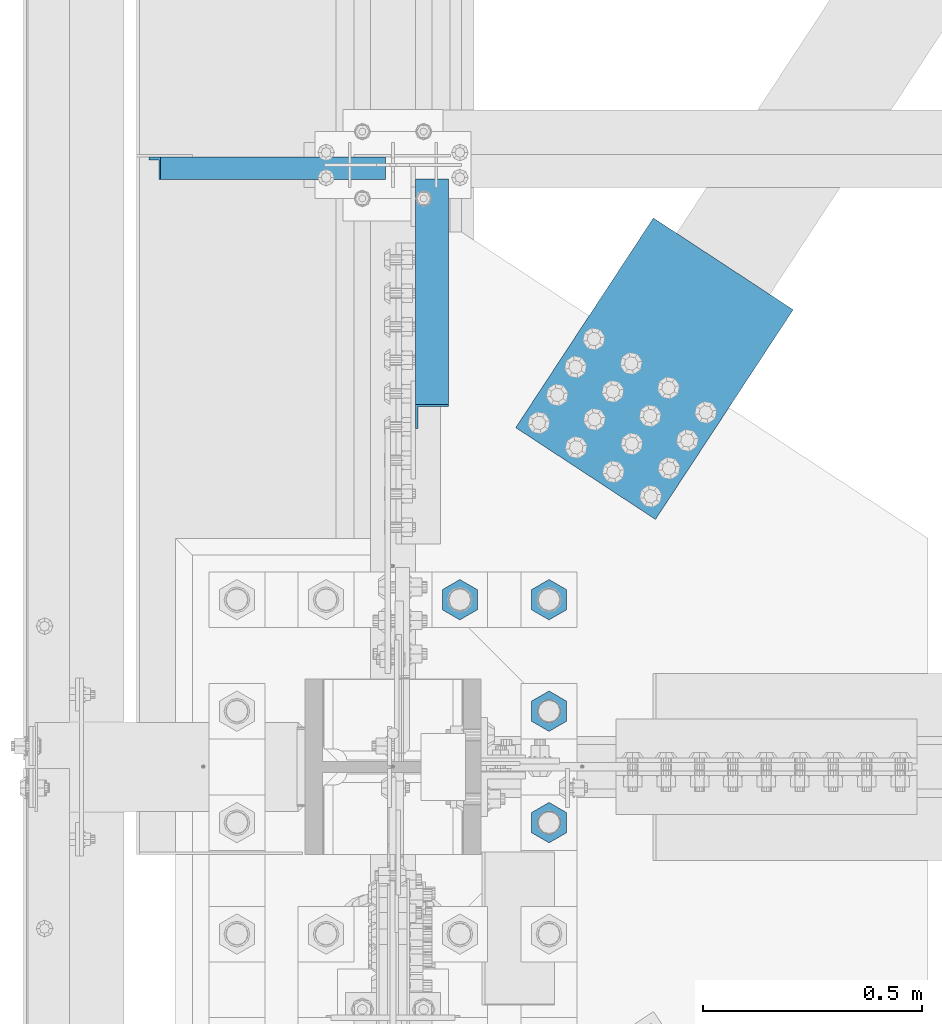
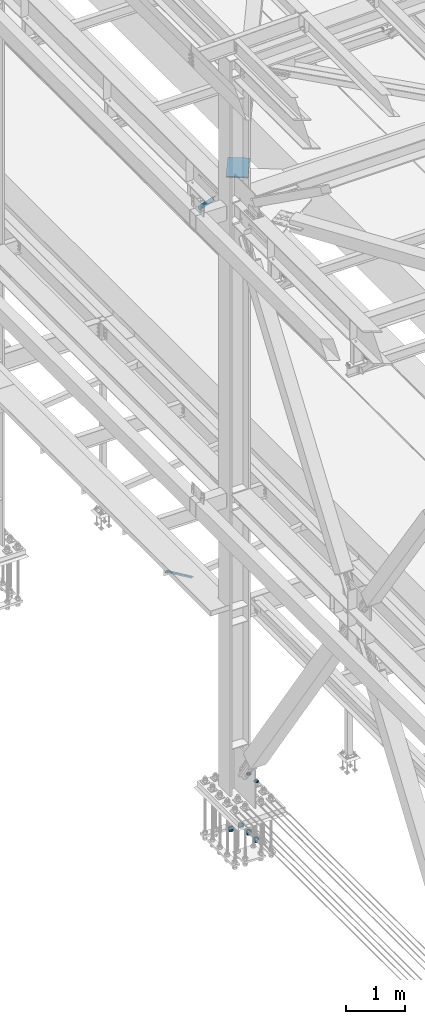
# One storey, part 2217 of 3843: 11 beams, 2 members, 4 elements without a shape of their own.
"""IFC2X3 building model written with IfcOpenShell, lengths in millimetres."""

from ifc_helpers import new_model, si_unit, frame, origin_with_axes, place, context, subcontext, project, spatial, faceted_brep, material, type_object, element, aggregate, save


model = new_model("IFC2X3")

# Units and contexts
model_context = context("Model", 3, precision=1e-05, world=origin_with_axes())
body_context = subcontext(model_context, "Body", "Model", "MODEL_VIEW")
ifc_project = project(units=[si_unit("LENGTHUNIT", "METRE", prefix="MILLI"), si_unit("AREAUNIT", "SQUARE_METRE"), si_unit("VOLUMEUNIT", "CUBIC_METRE"), si_unit("MASSUNIT", "GRAM", prefix="KILO"), si_unit("TIMEUNIT", "SECOND"), si_unit("PLANEANGLEUNIT", "RADIAN"), si_unit("SOLIDANGLEUNIT", "STERADIAN"), si_unit("THERMODYNAMICTEMPERATUREUNIT", "DEGREE_CELSIUS"), si_unit("LUMINOUSINTENSITYUNIT", "LUMEN")], contexts=[model_context])

# Site, building, storey
site_placement = place(None, origin_with_axes())
site = spatial("IfcSite", under=ifc_project, at=site_placement, CompositionType="ELEMENT")
building_placement = place(site_placement, origin_with_axes())
building = spatial("IfcBuilding", under=site, at=building_placement, Name="Undefined", CompositionType="ELEMENT")
storey_placement = place(building_placement, origin_with_axes())
storey = spatial("IfcBuildingStorey", under=building, at=storey_placement, Name="Undefined", CompositionType="ELEMENT", Elevation=0.0)

# Assembly, beams
assembly_1_placement = place(storey_placement, origin_with_axes())
assembly_1 = element("IfcElementAssembly", 1, at=assembly_1_placement, inside=storey, Name="TEMPLATE", AssemblyPlace="NOTDEFINED", PredefinedType="RIGID_FRAME")
ifc_material = material(Name="STEEL/A572-50")
beam_type_1 = type_object("IfcBeamType", Name="2_HALF_NUT", PredefinedType="NOTDEFINED")
beam_1_placement = place(assembly_1_placement, frame((36931.6, 59042.3, 30257.75), z_axis=(1.0, 0.0, 0.0), x_axis=(0.0, 0.0, -1.0)))
beam_1 = element("IfcBeam", 2, at=beam_1_placement, type_object=beam_type_1, material=ifc_material, Name="NUT", ObjectType="2_HALF_NUT", context=body_context, shape_type="Brep", body=[
    faceted_brep([(0.0, -46.0369987487793, 0.0), (0.0, -23.0184993743896, -39.869213104248), (25.4000000000015, -23.0184993743896, -39.869213104248), (25.4000000000015, -46.0369987487793, 0.0), (0.0, 23.0184993743896, -39.869213104248), (25.4000000000015, 23.0184993743896, -39.869213104248), (0.0, 46.0369987487793, 0.0), (25.4000000000015, 46.0369987487793, 0.0), (0.0, 23.0184993743896, 39.869213104248), (25.4000000000015, 23.0184993743896, 39.869213104248), (0.0, -23.0184993743896, 39.869213104248), (25.4000000000015, -23.0184993743896, 39.869213104248), (0.0, 0.0, 26.1940002441406), (0.0, 11.3650617044477, 23.5999013092805), (25.4000000000015, 11.3650617044477, 23.5999013092805), (25.4000000000015, 0.0, 26.1940002441406), (0.0, 20.4791109456419, 16.3316083006721), (25.4000000000015, 20.4791109456419, 16.3316083006721), (0.0, 25.5370200498292, 5.82867859874386), (25.4000000000015, 25.5370200498292, 5.82867859874386), (0.0, 25.5370200498292, -5.82867859874386), (25.4000000000015, 25.5370200498292, -5.82867859874386), (0.0, 20.4791109456419, -16.3316083006721), (25.4000000000015, 20.4791109456419, -16.3316083006721), (0.0, 11.3650617044477, -23.5999013092805), (25.4000000000015, 11.3650617044477, -23.5999013092805), (0.0, 0.0, -26.1940002441406), (25.4000000000015, 0.0, -26.1940002441406), (0.0, -11.3650617044477, -23.5999013092805), (25.4000000000015, -11.3650617044477, -23.5999013092805), (0.0, -20.4791109456419, -16.3316083006721), (25.4000000000015, -20.4791109456419, -16.3316083006721), (0.0, -25.5370200498292, -5.82867859874386), (25.4000000000015, -25.5370200498292, -5.82867859874386), (0.0, -25.5370200498292, 5.82867859874386), (25.4000000000015, -25.5370200498292, 5.82867859874386), (0.0, -20.4791109456419, 16.3316083006721), (25.4000000000015, -20.4791109456419, 16.3316083006721), (0.0, -11.3650617044477, 23.5999013092805), (25.4000000000015, -11.3650617044477, 23.5999013092805)], [[[0, 1, 2, 3]], [[1, 4, 5, 2]], [[4, 6, 7, 5]], [[6, 8, 9, 7]], [[8, 10, 11, 9]], [[10, 0, 3, 11]], [[12, 13, 14, 15]], [[13, 16, 17, 14]], [[16, 18, 19, 17]], [[18, 20, 21, 19]], [[20, 22, 23, 21]], [[22, 24, 25, 23]], [[24, 26, 27, 25]], [[26, 28, 29, 27]], [[28, 30, 31, 29]], [[30, 32, 33, 31]], [[32, 34, 35, 33]], [[34, 36, 37, 35]], [[36, 38, 39, 37]], [[38, 12, 15, 39]], [[5, 7, 9, 11, 3, 2], [17, 19, 21, 23, 25, 27, 29, 31, 33, 35, 37, 39, 15, 14]], [[10, 8, 6, 4, 1, 0], [38, 36, 34, 32, 30, 28, 26, 24, 22, 20, 18, 16, 13, 12]]]),
])
beam_2_placement = place(assembly_1_placement, frame((36931.6, 58788.3, 30257.75), z_axis=(1.0, 0.0, 0.0), x_axis=(0.0, 0.0, -1.0)))
beam_2 = element("IfcBeam", 3, at=beam_2_placement, type_object=beam_type_1, material=ifc_material, Name="NUT", ObjectType="2_HALF_NUT", context=body_context, shape_type="Brep", body=[
    faceted_brep([(0.0, -46.0369987487793, 0.0), (0.0, -23.0184993743896, -39.869213104248), (25.4000000000015, -23.0184993743896, -39.869213104248), (25.4000000000015, -46.0369987487793, 0.0), (0.0, 23.0184993743896, -39.869213104248), (25.4000000000015, 23.0184993743896, -39.869213104248), (0.0, 46.0369987487793, 0.0), (25.4000000000015, 46.0369987487793, 0.0), (0.0, 23.0184993743896, 39.869213104248), (25.4000000000015, 23.0184993743896, 39.869213104248), (0.0, -23.0184993743896, 39.869213104248), (25.4000000000015, -23.0184993743896, 39.869213104248), (0.0, 0.0, 26.1940002441406), (0.0, 11.3650617044477, 23.5999013092805), (25.4000000000015, 11.3650617044477, 23.5999013092805), (25.4000000000015, 0.0, 26.1940002441406), (0.0, 20.4791109456419, 16.3316083006721), (25.4000000000015, 20.4791109456419, 16.3316083006721), (0.0, 25.5370200498292, 5.82867859874386), (25.4000000000015, 25.5370200498292, 5.82867859874386), (0.0, 25.5370200498292, -5.82867859874386), (25.4000000000015, 25.5370200498292, -5.82867859874386), (0.0, 20.4791109456419, -16.3316083006721), (25.4000000000015, 20.4791109456419, -16.3316083006721), (0.0, 11.3650617044477, -23.5999013092805), (25.4000000000015, 11.3650617044477, -23.5999013092805), (0.0, 0.0, -26.1940002441406), (25.4000000000015, 0.0, -26.1940002441406), (0.0, -11.3650617044477, -23.5999013092805), (25.4000000000015, -11.3650617044477, -23.5999013092805), (0.0, -20.4791109456419, -16.3316083006721), (25.4000000000015, -20.4791109456419, -16.3316083006721), (0.0, -25.5370200498292, -5.82867859874386), (25.4000000000015, -25.5370200498292, -5.82867859874386), (0.0, -25.5370200498292, 5.82867859874386), (25.4000000000015, -25.5370200498292, 5.82867859874386), (0.0, -20.4791109456419, 16.3316083006721), (25.4000000000015, -20.4791109456419, 16.3316083006721), (0.0, -11.3650617044477, 23.5999013092805), (25.4000000000015, -11.3650617044477, 23.5999013092805)], [[[0, 1, 2, 3]], [[1, 4, 5, 2]], [[4, 6, 7, 5]], [[6, 8, 9, 7]], [[8, 10, 11, 9]], [[10, 0, 3, 11]], [[12, 13, 14, 15]], [[13, 16, 17, 14]], [[16, 18, 19, 17]], [[18, 20, 21, 19]], [[20, 22, 23, 21]], [[22, 24, 25, 23]], [[24, 26, 27, 25]], [[26, 28, 29, 27]], [[28, 30, 31, 29]], [[30, 32, 33, 31]], [[32, 34, 35, 33]], [[34, 36, 37, 35]], [[36, 38, 39, 37]], [[38, 12, 15, 39]], [[5, 7, 9, 11, 3, 2], [17, 19, 21, 23, 25, 27, 29, 31, 33, 35, 37, 39, 15, 14]], [[10, 8, 6, 4, 1, 0], [38, 36, 34, 32, 30, 28, 26, 24, 22, 20, 18, 16, 13, 12]]]),
])
beam_3_placement = place(assembly_1_placement, frame((36931.6, 59296.3, 29057.6), z_axis=(1.0, 0.0, 0.0), x_axis=(0.0, 0.0, -1.0)))
beam_3 = element("IfcBeam", 4, at=beam_3_placement, type_object=beam_type_1, material=ifc_material, Name="NUT", ObjectType="2_HALF_NUT", context=body_context, shape_type="Brep", body=[
    faceted_brep([(0.0, -46.0369987487793, 0.0), (0.0, -23.0184993743896, -39.869213104248), (25.4000000000015, -23.0184993743896, -39.869213104248), (25.4000000000015, -46.0369987487793, 0.0), (0.0, 23.0184993743896, -39.869213104248), (25.4000000000015, 23.0184993743896, -39.869213104248), (0.0, 46.0369987487793, 0.0), (25.4000000000015, 46.0369987487793, 0.0), (0.0, 23.0184993743896, 39.869213104248), (25.4000000000015, 23.0184993743896, 39.869213104248), (0.0, -23.0184993743896, 39.869213104248), (25.4000000000015, -23.0184993743896, 39.869213104248), (0.0, 0.0, 26.1940002441406), (0.0, 11.3650617044477, 23.5999013092805), (25.4000000000015, 11.3650617044477, 23.5999013092805), (25.4000000000015, 0.0, 26.1940002441406), (0.0, 20.4791109456419, 16.3316083006721), (25.4000000000015, 20.4791109456419, 16.3316083006721), (0.0, 25.5370200498292, 5.82867859874386), (25.4000000000015, 25.5370200498292, 5.82867859874386), (0.0, 25.5370200498292, -5.82867859874386), (25.4000000000015, 25.5370200498292, -5.82867859874386), (0.0, 20.4791109456419, -16.3316083006721), (25.4000000000015, 20.4791109456419, -16.3316083006721), (0.0, 11.3650617044477, -23.5999013092805), (25.4000000000015, 11.3650617044477, -23.5999013092805), (0.0, 0.0, -26.1940002441406), (25.4000000000015, 0.0, -26.1940002441406), (0.0, -11.3650617044477, -23.5999013092805), (25.4000000000015, -11.3650617044477, -23.5999013092805), (0.0, -20.4791109456419, -16.3316083006721), (25.4000000000015, -20.4791109456419, -16.3316083006721), (0.0, -25.5370200498292, -5.82867859874386), (25.4000000000015, -25.5370200498292, -5.82867859874386), (0.0, -25.5370200498292, 5.82867859874386), (25.4000000000015, -25.5370200498292, 5.82867859874386), (0.0, -20.4791109456419, 16.3316083006721), (25.4000000000015, -20.4791109456419, 16.3316083006721), (0.0, -11.3650617044477, 23.5999013092805), (25.4000000000015, -11.3650617044477, 23.5999013092805)], [[[0, 1, 2, 3]], [[1, 4, 5, 2]], [[4, 6, 7, 5]], [[6, 8, 9, 7]], [[8, 10, 11, 9]], [[10, 0, 3, 11]], [[12, 13, 14, 15]], [[13, 16, 17, 14]], [[16, 18, 19, 17]], [[18, 20, 21, 19]], [[20, 22, 23, 21]], [[22, 24, 25, 23]], [[24, 26, 27, 25]], [[26, 28, 29, 27]], [[28, 30, 31, 29]], [[30, 32, 33, 31]], [[32, 34, 35, 33]], [[34, 36, 37, 35]], [[36, 38, 39, 37]], [[38, 12, 15, 39]], [[5, 7, 9, 11, 3, 2], [17, 19, 21, 23, 25, 27, 29, 31, 33, 35, 37, 39, 15, 14]], [[10, 8, 6, 4, 1, 0], [38, 36, 34, 32, 30, 28, 26, 24, 22, 20, 18, 16, 13, 12]]]),
])
beam_4_placement = place(assembly_1_placement, frame((36728.4, 59296.3, 29057.6), z_axis=(1.0, 0.0, 0.0), x_axis=(0.0, 0.0, -1.0)))
beam_4 = element("IfcBeam", 5, at=beam_4_placement, type_object=beam_type_1, material=ifc_material, Name="NUT", ObjectType="2_HALF_NUT", context=body_context, shape_type="Brep", body=[
    faceted_brep([(0.0, -46.0369987487793, 0.0), (0.0, -23.0184993743896, -39.869213104248), (25.4000000000015, -23.0184993743896, -39.869213104248), (25.4000000000015, -46.0369987487793, 0.0), (0.0, 23.0184993743896, -39.869213104248), (25.4000000000015, 23.0184993743896, -39.869213104248), (0.0, 46.0369987487793, 0.0), (25.4000000000015, 46.0369987487793, 0.0), (0.0, 23.0184993743896, 39.869213104248), (25.4000000000015, 23.0184993743896, 39.869213104248), (0.0, -23.0184993743896, 39.869213104248), (25.4000000000015, -23.0184993743896, 39.869213104248), (0.0, 0.0, 26.1940002441406), (0.0, 11.3650617044477, 23.5999013092805), (25.4000000000015, 11.3650617044477, 23.5999013092805), (25.4000000000015, 0.0, 26.1940002441406), (0.0, 20.4791109456419, 16.3316083006721), (25.4000000000015, 20.4791109456419, 16.3316083006721), (0.0, 25.5370200498292, 5.82867859874386), (25.4000000000015, 25.5370200498292, 5.82867859874386), (0.0, 25.5370200498292, -5.82867859874386), (25.4000000000015, 25.5370200498292, -5.82867859874386), (0.0, 20.4791109456419, -16.3316083006721), (25.4000000000015, 20.4791109456419, -16.3316083006721), (0.0, 11.3650617044477, -23.5999013092805), (25.4000000000015, 11.3650617044477, -23.5999013092805), (0.0, 0.0, -26.1940002441406), (25.4000000000015, 0.0, -26.1940002441406), (0.0, -11.3650617044477, -23.5999013092805), (25.4000000000015, -11.3650617044477, -23.5999013092805), (0.0, -20.4791109456419, -16.3316083006721), (25.4000000000015, -20.4791109456419, -16.3316083006721), (0.0, -25.5370200498292, -5.82867859874386), (25.4000000000015, -25.5370200498292, -5.82867859874386), (0.0, -25.5370200498292, 5.82867859874386), (25.4000000000015, -25.5370200498292, 5.82867859874386), (0.0, -20.4791109456419, 16.3316083006721), (25.4000000000015, -20.4791109456419, 16.3316083006721), (0.0, -11.3650617044477, 23.5999013092805), (25.4000000000015, -11.3650617044477, 23.5999013092805)], [[[0, 1, 2, 3]], [[1, 4, 5, 2]], [[4, 6, 7, 5]], [[6, 8, 9, 7]], [[8, 10, 11, 9]], [[10, 0, 3, 11]], [[12, 13, 14, 15]], [[13, 16, 17, 14]], [[16, 18, 19, 17]], [[18, 20, 21, 19]], [[20, 22, 23, 21]], [[22, 24, 25, 23]], [[24, 26, 27, 25]], [[26, 28, 29, 27]], [[28, 30, 31, 29]], [[30, 32, 33, 31]], [[32, 34, 35, 33]], [[34, 36, 37, 35]], [[36, 38, 39, 37]], [[38, 12, 15, 39]], [[5, 7, 9, 11, 3, 2], [17, 19, 21, 23, 25, 27, 29, 31, 33, 35, 37, 39, 15, 14]], [[10, 8, 6, 4, 1, 0], [38, 36, 34, 32, 30, 28, 26, 24, 22, 20, 18, 16, 13, 12]]]),
])
beam_5_placement = place(assembly_1_placement, frame((36931.6, 59042.3, 29070.3), z_axis=(1.0, 0.0, 0.0), x_axis=(0.0, 0.0, -1.0)))
beam_5 = element("IfcBeam", 6, at=beam_5_placement, type_object=beam_type_1, material=ifc_material, Name="NUT", ObjectType="2_HALF_NUT", context=body_context, shape_type="Brep", body=[
    faceted_brep([(0.0, -46.0369987487793, 0.0), (0.0, -23.0184993743896, -39.869213104248), (25.4000000000015, -23.0184993743896, -39.869213104248), (25.4000000000015, -46.0369987487793, 0.0), (0.0, 23.0184993743896, -39.869213104248), (25.4000000000015, 23.0184993743896, -39.869213104248), (0.0, 46.0369987487793, 0.0), (25.4000000000015, 46.0369987487793, 0.0), (0.0, 23.0184993743896, 39.869213104248), (25.4000000000015, 23.0184993743896, 39.869213104248), (0.0, -23.0184993743896, 39.869213104248), (25.4000000000015, -23.0184993743896, 39.869213104248), (0.0, 0.0, 26.1940002441406), (0.0, 11.3650617044477, 23.5999013092805), (25.4000000000015, 11.3650617044477, 23.5999013092805), (25.4000000000015, 0.0, 26.1940002441406), (0.0, 20.4791109456419, 16.3316083006721), (25.4000000000015, 20.4791109456419, 16.3316083006721), (0.0, 25.5370200498292, 5.82867859874386), (25.4000000000015, 25.5370200498292, 5.82867859874386), (0.0, 25.5370200498292, -5.82867859874386), (25.4000000000015, 25.5370200498292, -5.82867859874386), (0.0, 20.4791109456419, -16.3316083006721), (25.4000000000015, 20.4791109456419, -16.3316083006721), (0.0, 11.3650617044477, -23.5999013092805), (25.4000000000015, 11.3650617044477, -23.5999013092805), (0.0, 0.0, -26.1940002441406), (25.4000000000015, 0.0, -26.1940002441406), (0.0, -11.3650617044477, -23.5999013092805), (25.4000000000015, -11.3650617044477, -23.5999013092805), (0.0, -20.4791109456419, -16.3316083006721), (25.4000000000015, -20.4791109456419, -16.3316083006721), (0.0, -25.5370200498292, -5.82867859874386), (25.4000000000015, -25.5370200498292, -5.82867859874386), (0.0, -25.5370200498292, 5.82867859874386), (25.4000000000015, -25.5370200498292, 5.82867859874386), (0.0, -20.4791109456419, 16.3316083006721), (25.4000000000015, -20.4791109456419, 16.3316083006721), (0.0, -11.3650617044477, 23.5999013092805), (25.4000000000015, -11.3650617044477, 23.5999013092805)], [[[0, 1, 2, 3]], [[1, 4, 5, 2]], [[4, 6, 7, 5]], [[6, 8, 9, 7]], [[8, 10, 11, 9]], [[10, 0, 3, 11]], [[12, 13, 14, 15]], [[13, 16, 17, 14]], [[16, 18, 19, 17]], [[18, 20, 21, 19]], [[20, 22, 23, 21]], [[22, 24, 25, 23]], [[24, 26, 27, 25]], [[26, 28, 29, 27]], [[28, 30, 31, 29]], [[30, 32, 33, 31]], [[32, 34, 35, 33]], [[34, 36, 37, 35]], [[36, 38, 39, 37]], [[38, 12, 15, 39]], [[5, 7, 9, 11, 3, 2], [17, 19, 21, 23, 25, 27, 29, 31, 33, 35, 37, 39, 15, 14]], [[10, 8, 6, 4, 1, 0], [38, 36, 34, 32, 30, 28, 26, 24, 22, 20, 18, 16, 13, 12]]]),
])
beam_6_placement = place(assembly_1_placement, frame((36931.6, 58788.3, 29070.3), z_axis=(1.0, 0.0, 0.0), x_axis=(0.0, 0.0, -1.0)))
beam_6 = element("IfcBeam", 7, at=beam_6_placement, type_object=beam_type_1, material=ifc_material, Name="NUT", ObjectType="2_HALF_NUT", context=body_context, shape_type="Brep", body=[
    faceted_brep([(0.0, -46.0369987487793, 0.0), (0.0, -23.0184993743896, -39.869213104248), (25.4000000000015, -23.0184993743896, -39.869213104248), (25.4000000000015, -46.0369987487793, 0.0), (0.0, 23.0184993743896, -39.869213104248), (25.4000000000015, 23.0184993743896, -39.869213104248), (0.0, 46.0369987487793, 0.0), (25.4000000000015, 46.0369987487793, 0.0), (0.0, 23.0184993743896, 39.869213104248), (25.4000000000015, 23.0184993743896, 39.869213104248), (0.0, -23.0184993743896, 39.869213104248), (25.4000000000015, -23.0184993743896, 39.869213104248), (0.0, 0.0, 26.1940002441406), (0.0, 11.3650617044477, 23.5999013092805), (25.4000000000015, 11.3650617044477, 23.5999013092805), (25.4000000000015, 0.0, 26.1940002441406), (0.0, 20.4791109456419, 16.3316083006721), (25.4000000000015, 20.4791109456419, 16.3316083006721), (0.0, 25.5370200498292, 5.82867859874386), (25.4000000000015, 25.5370200498292, 5.82867859874386), (0.0, 25.5370200498292, -5.82867859874386), (25.4000000000015, 25.5370200498292, -5.82867859874386), (0.0, 20.4791109456419, -16.3316083006721), (25.4000000000015, 20.4791109456419, -16.3316083006721), (0.0, 11.3650617044477, -23.5999013092805), (25.4000000000015, 11.3650617044477, -23.5999013092805), (0.0, 0.0, -26.1940002441406), (25.4000000000015, 0.0, -26.1940002441406), (0.0, -11.3650617044477, -23.5999013092805), (25.4000000000015, -11.3650617044477, -23.5999013092805), (0.0, -20.4791109456419, -16.3316083006721), (25.4000000000015, -20.4791109456419, -16.3316083006721), (0.0, -25.5370200498292, -5.82867859874386), (25.4000000000015, -25.5370200498292, -5.82867859874386), (0.0, -25.5370200498292, 5.82867859874386), (25.4000000000015, -25.5370200498292, 5.82867859874386), (0.0, -20.4791109456419, 16.3316083006721), (25.4000000000015, -20.4791109456419, 16.3316083006721), (0.0, -11.3650617044477, 23.5999013092805), (25.4000000000015, -11.3650617044477, 23.5999013092805)], [[[0, 1, 2, 3]], [[1, 4, 5, 2]], [[4, 6, 7, 5]], [[6, 8, 9, 7]], [[8, 10, 11, 9]], [[10, 0, 3, 11]], [[12, 13, 14, 15]], [[13, 16, 17, 14]], [[16, 18, 19, 17]], [[18, 20, 21, 19]], [[20, 22, 23, 21]], [[22, 24, 25, 23]], [[24, 26, 27, 25]], [[26, 28, 29, 27]], [[28, 30, 31, 29]], [[30, 32, 33, 31]], [[32, 34, 35, 33]], [[34, 36, 37, 35]], [[36, 38, 39, 37]], [[38, 12, 15, 39]], [[5, 7, 9, 11, 3, 2], [17, 19, 21, 23, 25, 27, 29, 31, 33, 35, 37, 39, 15, 14]], [[10, 8, 6, 4, 1, 0], [38, 36, 34, 32, 30, 28, 26, 24, 22, 20, 18, 16, 13, 12]]]),
])
beam_type_2 = type_object("IfcBeamType", Name="2_HEAVY_HEX_NUT", PredefinedType="NOTDEFINED")
beam_7_placement = place(assembly_1_placement, frame((36931.6, 59296.3, 29032.2), z_axis=(1.0, 0.0, 0.0), x_axis=(0.0, 0.0, -1.0)))
beam_7 = element("IfcBeam", 8, at=beam_7_placement, type_object=beam_type_2, material=ifc_material, Name="NUT", ObjectType="2_HEAVY_HEX_NUT", context=body_context, shape_type="Brep", body=[
    faceted_brep([(0.0, -46.0369987487793, 0.0), (0.0, -23.0184993743896, -39.869213104248), (50.7999999999993, -23.0184993743896, -39.869213104248), (50.7999999999993, -46.0369987487793, 0.0), (0.0, 23.0184993743896, -39.869213104248), (50.7999999999993, 23.0184993743896, -39.869213104248), (0.0, 46.0369987487793, 0.0), (50.7999999999993, 46.0369987487793, 0.0), (0.0, 23.0184993743896, 39.869213104248), (50.7999999999993, 23.0184993743896, 39.869213104248), (0.0, -23.0184993743896, 39.869213104248), (50.7999999999993, -23.0184993743896, 39.869213104248), (0.0, 0.0, 26.1940002441406), (0.0, 11.3650617044477, 23.5999013092805), (50.7999999999993, 11.3650617044477, 23.5999013092805), (50.7999999999993, 0.0, 26.1940002441406), (0.0, 20.4791109456419, 16.3316083006721), (50.7999999999993, 20.4791109456419, 16.3316083006721), (0.0, 25.5370200498292, 5.82867859874386), (50.7999999999993, 25.5370200498292, 5.82867859874386), (0.0, 25.5370200498292, -5.82867859874386), (50.7999999999993, 25.5370200498292, -5.82867859874386), (0.0, 20.4791109456419, -16.3316083006721), (50.7999999999993, 20.4791109456419, -16.3316083006721), (0.0, 11.3650617044477, -23.5999013092805), (50.7999999999993, 11.3650617044477, -23.5999013092805), (0.0, 0.0, -26.1940002441406), (50.7999999999993, 0.0, -26.1940002441406), (0.0, -11.3650617044477, -23.5999013092805), (50.7999999999993, -11.3650617044477, -23.5999013092805), (0.0, -20.4791109456419, -16.3316083006721), (50.7999999999993, -20.4791109456419, -16.3316083006721), (0.0, -25.5370200498292, -5.82867859874386), (50.7999999999993, -25.5370200498292, -5.82867859874386), (0.0, -25.5370200498292, 5.82867859874386), (50.7999999999993, -25.5370200498292, 5.82867859874386), (0.0, -20.4791109456419, 16.3316083006721), (50.7999999999993, -20.4791109456419, 16.3316083006721), (0.0, -11.3650617044477, 23.5999013092805), (50.7999999999993, -11.3650617044477, 23.5999013092805)], [[[0, 1, 2, 3]], [[1, 4, 5, 2]], [[4, 6, 7, 5]], [[6, 8, 9, 7]], [[8, 10, 11, 9]], [[10, 0, 3, 11]], [[12, 13, 14, 15]], [[13, 16, 17, 14]], [[16, 18, 19, 17]], [[18, 20, 21, 19]], [[20, 22, 23, 21]], [[22, 24, 25, 23]], [[24, 26, 27, 25]], [[26, 28, 29, 27]], [[28, 30, 31, 29]], [[30, 32, 33, 31]], [[32, 34, 35, 33]], [[34, 36, 37, 35]], [[36, 38, 39, 37]], [[38, 12, 15, 39]], [[5, 7, 9, 11, 3, 2], [17, 19, 21, 23, 25, 27, 29, 31, 33, 35, 37, 39, 15, 14]], [[10, 8, 6, 4, 1, 0], [38, 36, 34, 32, 30, 28, 26, 24, 22, 20, 18, 16, 13, 12]]]),
])
beam_8_placement = place(assembly_1_placement, frame((36728.4, 59296.3, 29032.2), z_axis=(1.0, 0.0, 0.0), x_axis=(0.0, 0.0, -1.0)))
beam_8 = element("IfcBeam", 9, at=beam_8_placement, type_object=beam_type_2, material=ifc_material, Name="NUT", ObjectType="2_HEAVY_HEX_NUT", context=body_context, shape_type="Brep", body=[
    faceted_brep([(0.0, -46.0369987487793, 0.0), (0.0, -23.0184993743896, -39.869213104248), (50.7999999999993, -23.0184993743896, -39.869213104248), (50.7999999999993, -46.0369987487793, 0.0), (0.0, 23.0184993743896, -39.869213104248), (50.7999999999993, 23.0184993743896, -39.869213104248), (0.0, 46.0369987487793, 0.0), (50.7999999999993, 46.0369987487793, 0.0), (0.0, 23.0184993743896, 39.869213104248), (50.7999999999993, 23.0184993743896, 39.869213104248), (0.0, -23.0184993743896, 39.869213104248), (50.7999999999993, -23.0184993743896, 39.869213104248), (0.0, 0.0, 26.1940002441406), (0.0, 11.3650617044477, 23.5999013092805), (50.7999999999993, 11.3650617044477, 23.5999013092805), (50.7999999999993, 0.0, 26.1940002441406), (0.0, 20.4791109456419, 16.3316083006721), (50.7999999999993, 20.4791109456419, 16.3316083006721), (0.0, 25.5370200498292, 5.82867859874386), (50.7999999999993, 25.5370200498292, 5.82867859874386), (0.0, 25.5370200498292, -5.82867859874386), (50.7999999999993, 25.5370200498292, -5.82867859874386), (0.0, 20.4791109456419, -16.3316083006721), (50.7999999999993, 20.4791109456419, -16.3316083006721), (0.0, 11.3650617044477, -23.5999013092805), (50.7999999999993, 11.3650617044477, -23.5999013092805), (0.0, 0.0, -26.1940002441406), (50.7999999999993, 0.0, -26.1940002441406), (0.0, -11.3650617044477, -23.5999013092805), (50.7999999999993, -11.3650617044477, -23.5999013092805), (0.0, -20.4791109456419, -16.3316083006721), (50.7999999999993, -20.4791109456419, -16.3316083006721), (0.0, -25.5370200498292, -5.82867859874386), (50.7999999999993, -25.5370200498292, -5.82867859874386), (0.0, -25.5370200498292, 5.82867859874386), (50.7999999999993, -25.5370200498292, 5.82867859874386), (0.0, -20.4791109456419, 16.3316083006721), (50.7999999999993, -20.4791109456419, 16.3316083006721), (0.0, -11.3650617044477, 23.5999013092805), (50.7999999999993, -11.3650617044477, 23.5999013092805)], [[[0, 1, 2, 3]], [[1, 4, 5, 2]], [[4, 6, 7, 5]], [[6, 8, 9, 7]], [[8, 10, 11, 9]], [[10, 0, 3, 11]], [[12, 13, 14, 15]], [[13, 16, 17, 14]], [[16, 18, 19, 17]], [[18, 20, 21, 19]], [[20, 22, 23, 21]], [[22, 24, 25, 23]], [[24, 26, 27, 25]], [[26, 28, 29, 27]], [[28, 30, 31, 29]], [[30, 32, 33, 31]], [[32, 34, 35, 33]], [[34, 36, 37, 35]], [[36, 38, 39, 37]], [[38, 12, 15, 39]], [[5, 7, 9, 11, 3, 2], [17, 19, 21, 23, 25, 27, 29, 31, 33, 35, 37, 39, 15, 14]], [[10, 8, 6, 4, 1, 0], [38, 36, 34, 32, 30, 28, 26, 24, 22, 20, 18, 16, 13, 12]]]),
])
beam_9_placement = place(assembly_1_placement, frame((36931.6, 59042.3, 29044.9), z_axis=(1.0, 0.0, 0.0), x_axis=(0.0, 0.0, -1.0)))
beam_9 = element("IfcBeam", 10, at=beam_9_placement, type_object=beam_type_2, material=ifc_material, Name="NUT", ObjectType="2_HEAVY_HEX_NUT", context=body_context, shape_type="Brep", body=[
    faceted_brep([(0.0, -46.0369987487793, 0.0), (0.0, -23.0184993743896, -39.869213104248), (50.7999999999993, -23.0184993743896, -39.869213104248), (50.7999999999993, -46.0369987487793, 0.0), (0.0, 23.0184993743896, -39.869213104248), (50.7999999999993, 23.0184993743896, -39.869213104248), (0.0, 46.0369987487793, 0.0), (50.7999999999993, 46.0369987487793, 0.0), (0.0, 23.0184993743896, 39.869213104248), (50.7999999999993, 23.0184993743896, 39.869213104248), (0.0, -23.0184993743896, 39.869213104248), (50.7999999999993, -23.0184993743896, 39.869213104248), (0.0, 0.0, 26.1940002441406), (0.0, 11.3650617044477, 23.5999013092805), (50.7999999999993, 11.3650617044477, 23.5999013092805), (50.7999999999993, 0.0, 26.1940002441406), (0.0, 20.4791109456419, 16.3316083006721), (50.7999999999993, 20.4791109456419, 16.3316083006721), (0.0, 25.5370200498292, 5.82867859874386), (50.7999999999993, 25.5370200498292, 5.82867859874386), (0.0, 25.5370200498292, -5.82867859874386), (50.7999999999993, 25.5370200498292, -5.82867859874386), (0.0, 20.4791109456419, -16.3316083006721), (50.7999999999993, 20.4791109456419, -16.3316083006721), (0.0, 11.3650617044477, -23.5999013092805), (50.7999999999993, 11.3650617044477, -23.5999013092805), (0.0, 0.0, -26.1940002441406), (50.7999999999993, 0.0, -26.1940002441406), (0.0, -11.3650617044477, -23.5999013092805), (50.7999999999993, -11.3650617044477, -23.5999013092805), (0.0, -20.4791109456419, -16.3316083006721), (50.7999999999993, -20.4791109456419, -16.3316083006721), (0.0, -25.5370200498292, -5.82867859874386), (50.7999999999993, -25.5370200498292, -5.82867859874386), (0.0, -25.5370200498292, 5.82867859874386), (50.7999999999993, -25.5370200498292, 5.82867859874386), (0.0, -20.4791109456419, 16.3316083006721), (50.7999999999993, -20.4791109456419, 16.3316083006721), (0.0, -11.3650617044477, 23.5999013092805), (50.7999999999993, -11.3650617044477, 23.5999013092805)], [[[0, 1, 2, 3]], [[1, 4, 5, 2]], [[4, 6, 7, 5]], [[6, 8, 9, 7]], [[8, 10, 11, 9]], [[10, 0, 3, 11]], [[12, 13, 14, 15]], [[13, 16, 17, 14]], [[16, 18, 19, 17]], [[18, 20, 21, 19]], [[20, 22, 23, 21]], [[22, 24, 25, 23]], [[24, 26, 27, 25]], [[26, 28, 29, 27]], [[28, 30, 31, 29]], [[30, 32, 33, 31]], [[32, 34, 35, 33]], [[34, 36, 37, 35]], [[36, 38, 39, 37]], [[38, 12, 15, 39]], [[5, 7, 9, 11, 3, 2], [17, 19, 21, 23, 25, 27, 29, 31, 33, 35, 37, 39, 15, 14]], [[10, 8, 6, 4, 1, 0], [38, 36, 34, 32, 30, 28, 26, 24, 22, 20, 18, 16, 13, 12]]]),
])
beam_10_placement = place(assembly_1_placement, frame((36931.6, 58788.3, 29044.9), z_axis=(1.0, 0.0, 0.0), x_axis=(0.0, 0.0, -1.0)))
beam_10 = element("IfcBeam", 11, at=beam_10_placement, type_object=beam_type_2, material=ifc_material, Name="NUT", ObjectType="2_HEAVY_HEX_NUT", context=body_context, shape_type="Brep", body=[
    faceted_brep([(0.0, -46.0369987487793, 0.0), (0.0, -23.0184993743896, -39.869213104248), (50.7999999999993, -23.0184993743896, -39.869213104248), (50.7999999999993, -46.0369987487793, 0.0), (0.0, 23.0184993743896, -39.869213104248), (50.7999999999993, 23.0184993743896, -39.869213104248), (0.0, 46.0369987487793, 0.0), (50.7999999999993, 46.0369987487793, 0.0), (0.0, 23.0184993743896, 39.869213104248), (50.7999999999993, 23.0184993743896, 39.869213104248), (0.0, -23.0184993743896, 39.869213104248), (50.7999999999993, -23.0184993743896, 39.869213104248), (0.0, 0.0, 26.1940002441406), (0.0, 11.3650617044477, 23.5999013092805), (50.7999999999993, 11.3650617044477, 23.5999013092805), (50.7999999999993, 0.0, 26.1940002441406), (0.0, 20.4791109456419, 16.3316083006721), (50.7999999999993, 20.4791109456419, 16.3316083006721), (0.0, 25.5370200498292, 5.82867859874386), (50.7999999999993, 25.5370200498292, 5.82867859874386), (0.0, 25.5370200498292, -5.82867859874386), (50.7999999999993, 25.5370200498292, -5.82867859874386), (0.0, 20.4791109456419, -16.3316083006721), (50.7999999999993, 20.4791109456419, -16.3316083006721), (0.0, 11.3650617044477, -23.5999013092805), (50.7999999999993, 11.3650617044477, -23.5999013092805), (0.0, 0.0, -26.1940002441406), (50.7999999999993, 0.0, -26.1940002441406), (0.0, -11.3650617044477, -23.5999013092805), (50.7999999999993, -11.3650617044477, -23.5999013092805), (0.0, -20.4791109456419, -16.3316083006721), (50.7999999999993, -20.4791109456419, -16.3316083006721), (0.0, -25.5370200498292, -5.82867859874386), (50.7999999999993, -25.5370200498292, -5.82867859874386), (0.0, -25.5370200498292, 5.82867859874386), (50.7999999999993, -25.5370200498292, 5.82867859874386), (0.0, -20.4791109456419, 16.3316083006721), (50.7999999999993, -20.4791109456419, 16.3316083006721), (0.0, -11.3650617044477, 23.5999013092805), (50.7999999999993, -11.3650617044477, 23.5999013092805)], [[[0, 1, 2, 3]], [[1, 4, 5, 2]], [[4, 6, 7, 5]], [[6, 8, 9, 7]], [[8, 10, 11, 9]], [[10, 0, 3, 11]], [[12, 13, 14, 15]], [[13, 16, 17, 14]], [[16, 18, 19, 17]], [[18, 20, 21, 19]], [[20, 22, 23, 21]], [[22, 24, 25, 23]], [[24, 26, 27, 25]], [[26, 28, 29, 27]], [[28, 30, 31, 29]], [[30, 32, 33, 31]], [[32, 34, 35, 33]], [[34, 36, 37, 35]], [[36, 38, 39, 37]], [[38, 12, 15, 39]], [[5, 7, 9, 11, 3, 2], [17, 19, 21, 23, 25, 27, 29, 31, 33, 35, 37, 39, 15, 14]], [[10, 8, 6, 4, 1, 0], [38, 36, 34, 32, 30, 28, 26, 24, 22, 20, 18, 16, 13, 12]]]),
])
aggregate(assembly_1, [beam_1, beam_2, beam_7, beam_3, beam_8, beam_4, beam_9, beam_10, beam_5, beam_6])

# Assembly, member
assembly_2_placement = place(storey_placement, origin_with_axes())
assembly_2 = element("IfcElementAssembly", 12, at=assembly_2_placement, inside=storey, Name="ANGLE", AssemblyPlace="NOTDEFINED", PredefinedType="RIGID_FRAME")
member_type_1 = type_object("IfcMemberType", Name="L2X2X1/4", PredefinedType="NOTDEFINED")
member_1_placement = place(assembly_2_placement, frame((36032.7062481198, 60279.458594, 34001.5027629153), z_axis=(0.0, -1.0, 0.0), x_axis=(0.858158898344811, 0.0, -0.513384169206278)))
member_1 = element("IfcMember", 13, at=member_1_placement, type_object=member_type_1, material=ifc_material, Name="ANGLE", ObjectType="L2X2X1/4", context=body_context, shape_type="Brep", body=[
    faceted_brep([(0.0, 25.4000000000015, -25.4000000000015), (0.0, 25.4000000000015, 25.4000000000015), (598.473132324763, 25.3999999988228, 25.3999999999942), (598.473132324763, 25.3999999988228, -25.3999999999942), (0.0, 19.0500000000029, 25.4000000000015), (598.473132324745, 19.0499999988242, 25.3999999999942), (0.0, 19.0500000000029, -19.0499999999993), (598.473132324745, 19.0499999988242, -19.0500000000029), (0.0, -25.4000000000015, -19.0499999999993), (598.473132324661, -25.4000000011511, -19.0500000000029), (0.0, -25.4000000000015, -25.4000000000015), (598.473132324661, -25.4000000011511, -25.3999999999942)], [[[0, 1, 2, 3]], [[1, 4, 5, 2]], [[4, 6, 7, 5]], [[6, 8, 9, 7]], [[8, 10, 11, 9]], [[10, 0, 3, 11]], [[5, 7, 9, 11, 3, 2]], [[10, 8, 6, 4, 1, 0]]]),
])
aggregate(assembly_2, [member_1])

assembly_3_placement = place(storey_placement, origin_with_axes())
assembly_3 = element("IfcElementAssembly", 14, at=assembly_3_placement, inside=storey, Name="ANGLE", AssemblyPlace="NOTDEFINED", PredefinedType="RIGID_FRAME")
member_type_2 = type_object("IfcMemberType", Name="L3X3X1/4", PredefinedType="NOTDEFINED")
member_2_placement = place(assembly_3_placement, frame((36664.9, 60286.9, 41300.4), z_axis=(0.0, -0.707106781186548, -0.707106781186548), x_axis=(0.0, -0.707106781186682, 0.707106781186413)))
member_2 = element("IfcMember", 15, at=member_2_placement, type_object=member_type_2, material=ifc_material, Name="ANGLE", ObjectType="L3X3X1/4", context=body_context, shape_type="Brep", body=[
    faceted_brep([(83.0012806675732, 38.0999999999985, -38.0999999999058), (83.0012806675732, -38.0999999999985, -38.0999999999058), (83.0012806675804, -38.0999999999985, -31.7499999999254), (83.0012806675804, 31.75, -31.7499999999254), (83.0012806675804, 31.75, 38.0999999999058), (83.0012806675804, 38.0999999999985, 38.0999999999058), (810.534203444928, 31.75, 38.0999999999112), (810.534203444928, 38.0999999999985, 38.0999999999112), (810.534203444538, 38.0999999999985, -38.099999999904), (810.534203444538, -38.0999999999985, -38.099999999904), (810.534203444575, -38.0999999999985, -31.7499999999272), (810.534203444575, 31.75, -31.7499999999272)], [[[0, 1, 2, 3, 4, 5]], [[5, 4, 6, 7]], [[0, 5, 7, 8]], [[1, 0, 8, 9]], [[2, 1, 9, 10]], [[3, 2, 10, 11]], [[4, 3, 11, 6]], [[10, 9, 8, 7, 6, 11]]]),
])
aggregate(assembly_3, [member_2])

# Assembly, beam
assembly_4_placement = place(storey_placement, origin_with_axes())
assembly_4 = element("IfcElementAssembly", 16, at=assembly_4_placement, inside=storey, AssemblyPlace="NOTDEFINED", PredefinedType="RIGID_FRAME")
beam_type_3 = type_object("IfcBeamType", PredefinedType="NOTDEFINED")
beam_11_placement = place(assembly_4_placement, frame((37014.9263609029, 59583.8498733905, 42259.2500000005), z_axis=(0.83593862902166, -0.548822930014214, 0.0), x_axis=(0.548822930014222, 0.835938629021655, 0.0)))
beam_11 = element("IfcBeam", 17, at=beam_11_placement, type_object=beam_type_3, material=ifc_material, Name="PLATE", context=body_context, shape_type="Brep", body=[
    faceted_brep([(5.85714587941766e-10, 12.6999999999971, -190.500000000349), (-6.14818418398499e-10, 12.6999999999971, 190.500000000364), (571.499999996191, 12.6999999999971, 190.49999999936), (571.499999997392, 12.6999999999971, -190.500000001353), (-6.14818418398499e-10, -12.6999999999971, 190.500000000364), (571.499999996191, -12.6999999999971, 190.49999999936), (5.85714587941766e-10, -12.6999999999971, -190.500000000349), (571.499999997392, -12.6999999999971, -190.500000001353)], [[[0, 1, 2, 3]], [[1, 4, 5, 2]], [[4, 6, 7, 5]], [[6, 0, 3, 7]], [[5, 7, 3, 2]], [[6, 4, 1, 0]]]),
])
aggregate(assembly_4, [beam_11])

save(model, "model.ifc")
